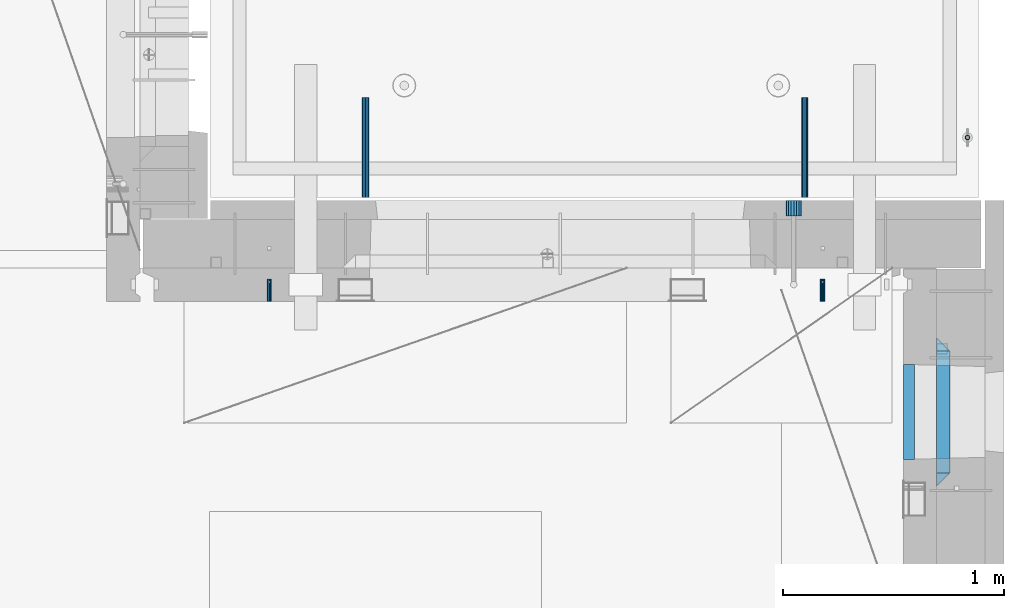
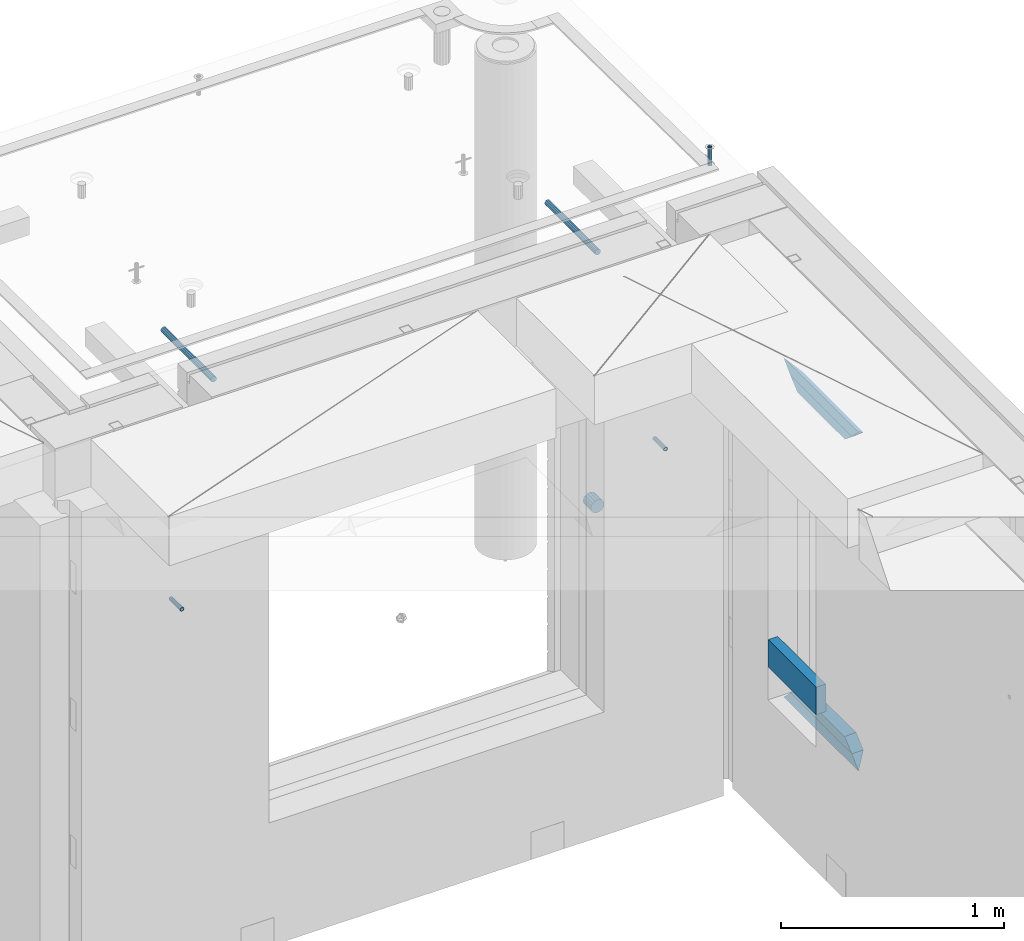
# One storey, part 163 of 334: 11 beams, 8 elements without a shape of their own.
"""IFC2X3 building model written with IfcOpenShell, lengths in millimetres."""

from ifc_helpers import new_model, si_unit, frame, origin_with_axes, place, context, subcontext, project, spatial, faceted_brep, material, type_object, element, aggregate, save


model = new_model("IFC2X3")

# Units and contexts
model_context = context("Model", 3, precision=1e-05, world=origin_with_axes())
body_context = subcontext(model_context, "Body", "Model", "MODEL_VIEW")
ifc_project = project(units=[si_unit("LENGTHUNIT", "METRE", prefix="MILLI"), si_unit("AREAUNIT", "SQUARE_METRE"), si_unit("VOLUMEUNIT", "CUBIC_METRE"), si_unit("MASSUNIT", "GRAM", prefix="KILO"), si_unit("TIMEUNIT", "SECOND"), si_unit("PLANEANGLEUNIT", "RADIAN"), si_unit("SOLIDANGLEUNIT", "STERADIAN"), si_unit("THERMODYNAMICTEMPERATUREUNIT", "DEGREE_CELSIUS"), si_unit("LUMINOUSINTENSITYUNIT", "LUMEN")], contexts=[model_context])

# Site, building, storey
site_placement = place(None, origin_with_axes())
site = spatial("IfcSite", under=ifc_project, at=site_placement, CompositionType="ELEMENT")
building_placement = place(site_placement, origin_with_axes())
building = spatial("IfcBuilding", under=site, at=building_placement, CompositionType="ELEMENT")
storey_placement = place(building_placement, origin_with_axes())
storey = spatial("IfcBuildingStorey", under=building, at=storey_placement, Name="3", CompositionType="ELEMENT", Elevation=0.0)

# Assemblies, beams
assembly_1_placement = place(storey_placement, origin_with_axes())
assembly_1 = element("IfcElementAssembly", 1, at=assembly_1_placement, inside=storey, AssemblyPlace="NOTDEFINED", PredefinedType="REINFORCEMENT_UNIT")
assembly_2_placement = place(assembly_1_placement, origin_with_axes())
assembly_2 = element("IfcElementAssembly", 2, at=assembly_2_placement, Name="Steel Assembly", AssemblyPlace="NOTDEFINED", PredefinedType="RIGID_FRAME")
ifc_material_1 = material(Name="STEEL/Steel_Undefined")
beam_type_1 = type_object("IfcBeamType", PredefinedType="NOTDEFINED")
beam_1_placement = place(assembly_2_placement, frame((32044.9982931989, 20429.9951872276, 89755.0), z_axis=(1.0, 0.0, 0.0), x_axis=(0.0, 1.0, 0.0)))
beam_1 = element("IfcBeam", 3, at=beam_1_placement, type_object=beam_type_1, material=ifc_material_1, Name="M16", context=body_context, shape_type="Brep", body=[
    faceted_brep([(0.0, -8.49999999999272, -1.45519152283669e-11), (0.0, -7.36121593215648, 4.24999999998545), (100.000000000262, -7.36121593215648, 4.24999999998545), (100.000000000262, -8.49999999999272, -1.45519152283669e-11), (0.0, -4.24999999998545, 7.36121593216376), (100.000000000262, -4.24999999998545, 7.36121593216376), (0.0, 1.45519152283669e-11, 8.49999999998545), (100.000000000262, 1.45519152283669e-11, 8.49999999998545), (0.0, 4.25000000001455, 7.36121593216376), (100.000000000262, 4.25000000001455, 7.36121593216376), (0.0, 7.36121593217104, 4.24999999998545), (100.000000000262, 7.36121593217104, 4.24999999998545), (0.0, 8.50000000000728, 0.0), (100.000000000262, 8.50000000000728, 0.0), (0.0, 7.36121593217104, -4.25000000001455), (100.000000000262, 7.36121593217104, -4.25000000001455), (0.0, 4.25000000000728, -7.36121593219286), (100.000000000262, 4.25000000000728, -7.36121593219286), (0.0, 7.27595761418343e-12, -8.5), (100.000000000262, 7.27595761418343e-12, -8.5), (0.0, -4.24999999999272, -7.36121593217831), (100.000000000262, -4.24999999999272, -7.36121593217831), (0.0, -7.36121593215648, -4.25), (100.000000000262, -7.36121593215648, -4.25), (0.0, -10.4999999999927, -1.45519152283669e-11), (0.0, -9.09326673972828, -5.25000000001455), (100.000000000262, -9.09326673972828, -5.25000000001455), (100.000000000262, -10.4999999999927, -1.45519152283669e-11), (0.0, -5.24999999998545, -9.09326673974283), (100.000000000262, -5.24999999998545, -9.09326673974283), (0.0, 7.27595761418343e-12, -10.5), (100.000000000262, 7.27595761418343e-12, -10.5), (0.0, 5.25000000001455, -9.09326673975738), (100.000000000262, 5.25000000001455, -9.09326673975738), (0.0, 9.09326673975011, -5.25000000001455), (100.000000000262, 9.09326673975011, -5.25000000001455), (0.0, 10.5000000000073, -1.45519152283669e-11), (100.000000000262, 10.5000000000073, -1.45519152283669e-11), (0.0, 9.09326673975011, 5.25), (100.000000000262, 9.09326673975011, 5.25), (0.0, 5.25000000000728, 9.09326673972828), (100.000000000262, 5.25000000000728, 9.09326673972828), (0.0, 1.45519152283669e-11, 10.4999999999854), (100.000000000262, 1.45519152283669e-11, 10.4999999999854), (0.0, -5.24999999999272, 9.09326673972828), (100.000000000262, -5.24999999999272, 9.09326673972828), (0.0, -9.09326673972828, 5.24999999998545), (100.000000000262, -9.09326673972828, 5.24999999998545)], [[[0, 1, 2, 3]], [[1, 4, 5, 2]], [[4, 6, 7, 5]], [[6, 8, 9, 7]], [[8, 10, 11, 9]], [[10, 12, 13, 11]], [[12, 14, 15, 13]], [[14, 16, 17, 15]], [[16, 18, 19, 17]], [[18, 20, 21, 19]], [[20, 22, 23, 21]], [[22, 0, 3, 23]], [[24, 25, 26, 27]], [[25, 28, 29, 26]], [[28, 30, 31, 29]], [[30, 32, 33, 31]], [[32, 34, 35, 33]], [[34, 36, 37, 35]], [[36, 38, 39, 37]], [[38, 40, 41, 39]], [[40, 42, 43, 41]], [[42, 44, 45, 43]], [[44, 46, 47, 45]], [[46, 24, 27, 47]], [[29, 31, 33, 35, 37, 39, 41, 43, 45, 47, 27, 26], [5, 7, 9, 11, 13, 15, 17, 19, 21, 23, 3, 2]], [[46, 44, 42, 40, 38, 36, 34, 32, 30, 28, 25, 24], [22, 20, 18, 16, 14, 12, 10, 8, 6, 4, 1, 0]]]),
])
aggregate(assembly_2, [beam_1])
assembly_3_placement = place(assembly_1_placement, origin_with_axes())
assembly_3 = element("IfcElementAssembly", 4, at=assembly_3_placement, Name="Steel Assembly", AssemblyPlace="NOTDEFINED", PredefinedType="RIGID_FRAME")
beam_2_placement = place(assembly_3_placement, frame((34544.998293199, 20429.9951872276, 89755.0), z_axis=(1.0, 0.0, 0.0), x_axis=(0.0, 1.0, 0.0)))
beam_2 = element("IfcBeam", 5, at=beam_2_placement, type_object=beam_type_1, material=ifc_material_1, Name="M16", context=body_context, shape_type="Brep", body=[
    faceted_brep([(0.0, -8.49999999999272, -1.45519152283669e-11), (0.0, -7.36121593215648, 4.24999999998545), (100.000000000262, -7.36121593215648, 4.24999999998545), (100.000000000262, -8.49999999999272, -1.45519152283669e-11), (0.0, -4.24999999998545, 7.36121593216376), (100.000000000262, -4.24999999998545, 7.36121593216376), (0.0, 1.45519152283669e-11, 8.49999999998545), (100.000000000262, 1.45519152283669e-11, 8.49999999998545), (0.0, 4.25000000001455, 7.36121593216376), (100.000000000262, 4.25000000001455, 7.36121593216376), (0.0, 7.36121593217104, 4.24999999998545), (100.000000000262, 7.36121593217104, 4.24999999998545), (0.0, 8.50000000000728, 0.0), (100.000000000262, 8.50000000000728, 0.0), (0.0, 7.36121593217104, -4.25000000001455), (100.000000000262, 7.36121593217104, -4.25000000001455), (0.0, 4.25000000000728, -7.36121593219286), (100.000000000262, 4.25000000000728, -7.36121593219286), (0.0, 7.27595761418343e-12, -8.5), (100.000000000262, 7.27595761418343e-12, -8.5), (0.0, -4.24999999999272, -7.36121593217831), (100.000000000262, -4.24999999999272, -7.36121593217831), (0.0, -7.36121593215648, -4.25), (100.000000000262, -7.36121593215648, -4.25), (0.0, -10.4999999999927, -1.45519152283669e-11), (0.0, -9.09326673972828, -5.25000000001455), (100.000000000262, -9.09326673972828, -5.25000000001455), (100.000000000262, -10.4999999999927, -1.45519152283669e-11), (0.0, -5.24999999998545, -9.09326673974283), (100.000000000262, -5.24999999998545, -9.09326673974283), (0.0, 7.27595761418343e-12, -10.5), (100.000000000262, 7.27595761418343e-12, -10.5), (0.0, 5.25000000001455, -9.09326673975738), (100.000000000262, 5.25000000001455, -9.09326673975738), (0.0, 9.09326673975011, -5.25000000001455), (100.000000000262, 9.09326673975011, -5.25000000001455), (0.0, 10.5000000000073, -1.45519152283669e-11), (100.000000000262, 10.5000000000073, -1.45519152283669e-11), (0.0, 9.09326673975011, 5.25), (100.000000000262, 9.09326673975011, 5.25), (0.0, 5.25000000000728, 9.09326673972828), (100.000000000262, 5.25000000000728, 9.09326673972828), (0.0, 1.45519152283669e-11, 10.4999999999854), (100.000000000262, 1.45519152283669e-11, 10.4999999999854), (0.0, -5.24999999999272, 9.09326673972828), (100.000000000262, -5.24999999999272, 9.09326673972828), (0.0, -9.09326673972828, 5.24999999998545), (100.000000000262, -9.09326673972828, 5.24999999998545)], [[[0, 1, 2, 3]], [[1, 4, 5, 2]], [[4, 6, 7, 5]], [[6, 8, 9, 7]], [[8, 10, 11, 9]], [[10, 12, 13, 11]], [[12, 14, 15, 13]], [[14, 16, 17, 15]], [[16, 18, 19, 17]], [[18, 20, 21, 19]], [[20, 22, 23, 21]], [[22, 0, 3, 23]], [[24, 25, 26, 27]], [[25, 28, 29, 26]], [[28, 30, 31, 29]], [[30, 32, 33, 31]], [[32, 34, 35, 33]], [[34, 36, 37, 35]], [[36, 38, 39, 37]], [[38, 40, 41, 39]], [[40, 42, 43, 41]], [[42, 44, 45, 43]], [[44, 46, 47, 45]], [[46, 24, 27, 47]], [[29, 31, 33, 35, 37, 39, 41, 43, 45, 47, 27, 26], [5, 7, 9, 11, 13, 15, 17, 19, 21, 23, 3, 2]], [[46, 44, 42, 40, 38, 36, 34, 32, 30, 28, 25, 24], [22, 20, 18, 16, 14, 12, 10, 8, 6, 4, 1, 0]]]),
])
aggregate(assembly_3, [beam_2])

# Assemblies, beam
assembly_4_placement = place(storey_placement, origin_with_axes())
assembly_4 = element("IfcElementAssembly", 6, at=assembly_4_placement, inside=storey, AssemblyPlace="NOTDEFINED", PredefinedType="REINFORCEMENT_UNIT")
assembly_5_placement = place(assembly_4_placement, origin_with_axes())
assembly_5 = element("IfcElementAssembly", 7, at=assembly_5_placement, Name="Steel Assembly", AssemblyPlace="NOTDEFINED", PredefinedType="RIGID_FRAME")
ifc_material_2 = material(Name="STEEL/1.4301")
beam_type_2 = type_object("IfcBeamType", PredefinedType="NOTDEFINED")
beam_3_placement = place(assembly_5_placement, frame((35199.9998195516, 21170.0002421324, 90731.000000009), z_axis=(0.999999999984675, 3.40399999908427e-06, -4.36599999368485e-06), x_axis=(-4.36599999292741e-06, 0.0, -0.999999999990469)))
beam_3 = element("IfcBeam", 8, at=beam_3_placement, type_object=beam_type_2, material=ifc_material_2, context=body_context, shape_type="Brep", body=[
    faceted_brep([(0.0, -8.0, 0.0), (0.0, -6.92820323027263, 4.0), (100.000000000029, -6.92820323027263, 4.0), (100.000000000029, -7.99999999999636, 0.0), (0.0, -4.0, 6.92820323027627), (100.000000000029, -4.0, 6.92820323027536), (0.0, 0.0, 8.0), (100.000000000029, 3.63797880709171e-12, 8.0), (0.0, 4.0, 6.92820323027627), (100.000000000029, 4.0, 6.92820323027536), (0.0, 6.92820323027263, 4.0), (100.000000000029, 6.92820323027627, 3.99999999999909), (0.0, 8.0, 0.0), (100.000000000029, 8.0, 0.0), (0.0, 6.92820323027263, -4.0), (100.000000000029, 6.92820323027627, -4.00000000000091), (0.0, 4.0, -6.92820323027627), (100.000000000029, 4.00000000000364, -6.92820323027536), (0.0, 0.0, -8.0), (100.000000000029, 3.63797880709171e-12, -8.00000000000091), (0.0, -4.0, -6.92820323027627), (100.000000000029, -3.99999999999636, -6.92820323027627), (0.0, -6.92820323027263, -4.0), (100.000000000029, -6.92820323027263, -4.0), (0.0, -10.4999999999927, -1.45519152283669e-11), (0.0, -9.09326673972828, -5.25000000001455), (100.000000000262, -9.09326673972828, -5.25000000001455), (100.000000000262, -10.4999999999927, -1.45519152283669e-11), (0.0, -5.24999999998545, -9.09326673974283), (100.000000000262, -5.24999999998545, -9.09326673974283), (0.0, 7.27595761418343e-12, -10.5), (100.000000000262, 7.27595761418343e-12, -10.5), (0.0, 5.25000000001455, -9.09326673975738), (100.000000000262, 5.25000000001455, -9.09326673975738), (0.0, 9.09326673975011, -5.25000000001455), (100.000000000262, 9.09326673975011, -5.25000000001455), (0.0, 10.5000000000073, -1.45519152283669e-11), (100.000000000262, 10.5000000000073, -1.45519152283669e-11), (0.0, 9.09326673975011, 5.25), (100.000000000262, 9.09326673975011, 5.25), (0.0, 5.25000000000728, 9.09326673972828), (100.000000000262, 5.25000000000728, 9.09326673972828), (0.0, 1.45519152283669e-11, 10.4999999999854), (100.000000000262, 1.45519152283669e-11, 10.4999999999854), (0.0, -5.24999999999272, 9.09326673972828), (100.000000000262, -5.24999999999272, 9.09326673972828), (0.0, -9.09326673972828, 5.24999999998545), (100.000000000262, -9.09326673972828, 5.24999999998545)], [[[0, 1, 2, 3]], [[1, 4, 5, 2]], [[4, 6, 7, 5]], [[6, 8, 9, 7]], [[8, 10, 11, 9]], [[10, 12, 13, 11]], [[12, 14, 15, 13]], [[14, 16, 17, 15]], [[16, 18, 19, 17]], [[18, 20, 21, 19]], [[20, 22, 23, 21]], [[22, 0, 3, 23]], [[24, 25, 26, 27]], [[25, 28, 29, 26]], [[28, 30, 31, 29]], [[30, 32, 33, 31]], [[32, 34, 35, 33]], [[34, 36, 37, 35]], [[36, 38, 39, 37]], [[38, 40, 41, 39]], [[40, 42, 43, 41]], [[42, 44, 45, 43]], [[44, 46, 47, 45]], [[46, 24, 27, 47]], [[29, 31, 33, 35, 37, 39, 41, 43, 45, 47, 27, 26], [5, 7, 9, 11, 13, 15, 17, 19, 21, 23, 3, 2]], [[46, 44, 42, 40, 38, 36, 34, 32, 30, 28, 25, 24], [22, 20, 18, 16, 14, 12, 10, 8, 6, 4, 1, 0]]]),
])
aggregate(assembly_5, [beam_3])

# Beam
ifc_material_3 = material()
beam_type_3 = type_object("IfcBeamType", Name="D70", PredefinedType="NOTDEFINED")
beam_4_placement = place(assembly_1_placement, frame((34415.0, 20884.9951872276, 89255.0), z_axis=(0.0, 0.0, 1.0), x_axis=(0.0, -1.0, 0.0)))
beam_4 = element("IfcBeam", 9, at=beam_4_placement, type_object=beam_type_3, material=ifc_material_3, ObjectType="D70", context=body_context, shape_type="Brep", body=[
    faceted_brep([(0.0, -35.0, 0.0), (0.0, -32.3357836378964, -13.3939201327739), (70.0, -32.3357836378964, -13.3939201327739), (70.0, -35.0, 0.0), (0.0, -24.7487373415279, -24.7487373415352), (70.0, -24.7487373415279, -24.7487373415352), (0.0, -13.3939201327776, -32.3357836379), (70.0, -13.3939201327776, -32.3357836379), (0.0, 0.0, -35.0), (70.0, 0.0, -35.0), (0.0, 13.3939201327776, -32.3357836379), (70.0, 13.3939201327776, -32.3357836379), (0.0, 24.7487373415279, -24.7487373415352), (70.0, 24.7487373415279, -24.7487373415352), (0.0, 32.3357836378964, -13.3939201327739), (70.0, 32.3357836378964, -13.3939201327739), (0.0, 35.0, 0.0), (70.0, 35.0, 0.0), (0.0, 32.3357836378964, 13.3939201327739), (70.0, 32.3357836378964, 13.3939201327739), (0.0, 24.7487373415279, 24.7487373415352), (70.0, 24.7487373415279, 24.7487373415352), (0.0, 13.3939201327776, 32.3357836379), (70.0, 13.3939201327776, 32.3357836379), (0.0, 0.0, 35.0), (70.0, 0.0, 35.0), (0.0, -13.3939201327776, 32.3357836379), (70.0, -13.3939201327776, 32.3357836379), (0.0, -24.7487373415279, 24.7487373415352), (70.0, -24.7487373415279, 24.7487373415352), (0.0, -32.3357836378964, 13.3939201327739), (70.0, -32.3357836378964, 13.3939201327739)], [[[0, 1, 2, 3]], [[1, 4, 5, 2]], [[4, 6, 7, 5]], [[6, 8, 9, 7]], [[8, 10, 11, 9]], [[10, 12, 13, 11]], [[12, 14, 15, 13]], [[14, 16, 17, 15]], [[16, 18, 19, 17]], [[18, 20, 21, 19]], [[20, 22, 23, 21]], [[22, 24, 25, 23]], [[24, 26, 27, 25]], [[26, 28, 29, 27]], [[28, 30, 31, 29]], [[30, 0, 3, 31]], [[5, 7, 9, 11, 13, 15, 17, 19, 21, 23, 25, 27, 29, 31, 3, 2]], [[30, 28, 26, 24, 22, 20, 18, 16, 14, 12, 10, 8, 6, 4, 1, 0]]]),
])

aggregate(assembly_1, [assembly_2, assembly_3, beam_4])

# Assembly, beam
assembly_6_placement = place(assembly_4_placement, origin_with_axes())
assembly_6 = element("IfcElementAssembly", 10, at=assembly_6_placement, Name="Steel Assembly", AssemblyPlace="NOTDEFINED", PredefinedType="RIGID_FRAME")
ifc_material_4 = material(Name="STEEL/S235JR")
beam_type_4 = type_object("IfcBeamType", Name="D30", PredefinedType="NOTDEFINED")
beam_5_placement = place(assembly_6_placement, frame((32479.9998567563, 20900.0253394533, 90575.0), z_axis=(0.0, 0.0, 1.0), x_axis=(0.0, 1.0, 0.0)))
beam_5 = element("IfcBeam", 11, at=beam_5_placement, type_object=beam_type_4, material=ifc_material_4, Name="Rd30", ObjectType="D30", context=body_context, shape_type="Brep", body=[
    faceted_brep([(0.0, -15.0, 0.0), (0.0, -12.9903810567666, -7.5), (450.0, -12.9903810567666, -7.5), (450.0, -15.0, 0.0), (0.0, -7.5, -12.9903810567666), (450.0, -7.5, -12.990381056763), (0.0, 0.0, -15.0), (450.0, 0.0, -15.0), (0.0, 7.5, -12.9903810567666), (450.0, 7.5, -12.990381056763), (0.0, 12.9903810567666, -7.5), (450.0, 12.9903810567666, -7.5), (0.0, 15.0, 0.0), (450.0, 15.0, 0.0), (0.0, 12.9903810567666, 7.5), (450.0, 12.9903810567666, 7.5), (0.0, 7.5, 12.9903810567666), (450.0, 7.5, 12.990381056763), (0.0, 0.0, 15.0), (450.0, 0.0, 15.0), (0.0, -7.5, 12.9903810567666), (450.0, -7.5, 12.990381056763), (0.0, -12.9903810567666, 7.5), (450.0, -12.9903810567666, 7.5)], [[[0, 1, 2, 3]], [[1, 4, 5, 2]], [[4, 6, 7, 5]], [[6, 8, 9, 7]], [[8, 10, 11, 9]], [[10, 12, 13, 11]], [[12, 14, 15, 13]], [[14, 16, 17, 15]], [[16, 18, 19, 17]], [[18, 20, 21, 19]], [[20, 22, 23, 21]], [[22, 0, 3, 23]], [[5, 7, 9, 11, 13, 15, 17, 19, 21, 23, 3, 2]], [[22, 20, 18, 16, 14, 12, 10, 8, 6, 4, 1, 0]]]),
])
aggregate(assembly_6, [beam_5])

# Assembly
assembly_7_placement = place(assembly_4_placement, origin_with_axes())
assembly_7 = element("IfcElementAssembly", 12, at=assembly_7_placement, Name="Steel Assembly", AssemblyPlace="NOTDEFINED", PredefinedType="RIGID_FRAME")

aggregate(assembly_4, [assembly_5, assembly_6, assembly_7])

# Beam
beam_6_placement = place(assembly_7_placement, frame((34464.9998570066, 20900.0152136098, 90575.0), z_axis=(0.0, 0.0, 1.0), x_axis=(0.0, 1.0, 0.0)))
beam_6 = element("IfcBeam", 13, at=beam_6_placement, type_object=beam_type_4, material=ifc_material_4, Name="Rd30", ObjectType="D30", context=body_context, shape_type="Brep", body=[
    faceted_brep([(0.0, -15.0, 0.0), (0.0, -12.9903810567666, -7.5), (450.0, -12.9903810567666, -7.5), (450.0, -15.0, 0.0), (0.0, -7.5, -12.9903810567666), (450.0, -7.5, -12.990381056763), (0.0, 0.0, -15.0), (450.0, 0.0, -15.0), (0.0, 7.5, -12.9903810567666), (450.0, 7.5, -12.990381056763), (0.0, 12.9903810567666, -7.5), (450.0, 12.9903810567666, -7.5), (0.0, 15.0, 0.0), (450.0, 15.0, 0.0), (0.0, 12.9903810567666, 7.5), (450.0, 12.9903810567666, 7.5), (0.0, 7.5, 12.9903810567666), (450.0, 7.5, 12.990381056763), (0.0, 0.0, 15.0), (450.0, 0.0, 15.0), (0.0, -7.5, 12.9903810567666), (450.0, -7.5, 12.990381056763), (0.0, -12.9903810567666, 7.5), (450.0, -12.9903810567666, 7.5)], [[[0, 1, 2, 3]], [[1, 4, 5, 2]], [[4, 6, 7, 5]], [[6, 8, 9, 7]], [[8, 10, 11, 9]], [[10, 12, 13, 11]], [[12, 14, 15, 13]], [[14, 16, 17, 15]], [[16, 18, 19, 17]], [[18, 20, 21, 19]], [[20, 22, 23, 21]], [[22, 0, 3, 23]], [[5, 7, 9, 11, 13, 15, 17, 19, 21, 23, 3, 2]], [[22, 20, 18, 16, 14, 12, 10, 8, 6, 4, 1, 0]]]),
])

aggregate(assembly_7, [beam_6])

# Assembly, beams
assembly_8_placement = place(storey_placement, origin_with_axes())
assembly_8 = element("IfcElementAssembly", 14, at=assembly_8_placement, inside=storey, AssemblyPlace="NOTDEFINED", PredefinedType="REINFORCEMENT_UNIT")
ifc_material_5 = material(Name="TIMBER/T24")
beam_type_5 = type_object("IfcBeamType", PredefinedType="NOTDEFINED")
beam_7_placement = place(assembly_8_placement, frame((34935.0002758707, 19715.0011464907, 88685.0), z_axis=(0.0, 0.0, 1.0), x_axis=(0.0, 1.0, 0.0)))
beam_7 = element("IfcBeam", 15, at=beam_7_placement, type_object=beam_type_5, material=ifc_material_5, context=body_context, shape_type="Brep", body=[
    faceted_brep([(-3.63797880709171e-12, 24.9999999999964, -75.0), (-3.63797880709171e-12, 24.9999999999964, 75.0), (430.0, 25.0, 75.0), (430.0, 25.0, -75.0), (0.0, -25.0000000000073, 75.0), (430.0, -25.0, 75.0), (0.0, -25.0000000000073, -75.0), (430.0, -25.0, -75.0)], [[[0, 1, 2, 3]], [[1, 4, 5, 2]], [[4, 6, 7, 5]], [[6, 0, 3, 7]], [[5, 7, 3, 2]], [[6, 4, 1, 0]]]),
])
ifc_material_6 = material(Name="CONCRETE/C25/30")
beam_type_6 = type_object("IfcBeamType", PredefinedType="NOTDEFINED")
beam_8_placement = place(assembly_8_placement, frame((35090.0, 19595.0003479451, 90145.0), z_axis=(0.0, 0.0, -1.0), x_axis=(0.0, 1.0, 0.0)))
beam_8 = element("IfcBeam", 16, at=beam_8_placement, type_object=beam_type_6, material=ifc_material_6, Name="SK", context=body_context, shape_type="Brep", body=[
    faceted_brep([(60.0000000000073, 30.0, 30.0), (0.0, -30.0, -30.0), (60.0000000000073, -30.0, 30.0), (609.999618530263, 30.0, 30.0), (669.999575761092, -30.0, -30.0), (609.999618530263, -30.0, 30.0)], [[[0, 1, 2]], [[1, 0, 3, 4]], [[2, 1, 4, 5]], [[0, 2, 5, 3]], [[4, 3, 5]]]),
])
beam_9_placement = place(assembly_8_placement, frame((35090.0, 19655.0003479451, 90085.0), z_axis=(0.0, 0.0, -1.0), x_axis=(0.0, 1.0, 0.0)))
beam_9 = element("IfcBeam", 17, at=beam_9_placement, type_object=beam_type_6, material=ifc_material_6, Name="SK", context=body_context, shape_type="Brep", body=[
    faceted_brep([(65.6752942059502, 30.0, 25.6756756756804), (64.0536725843267, -30.0, 24.0540540540533), (485.94556447622, -30.0, 24.0540540540533), (484.323942854597, 30.0, 25.6756756756804), (65.6752942059502, 30.0, 26.293109307022), (64.0536725843267, -30.0, 24.9031479173718), (0.0, -30.0, -30.0), (0.0, 30.0, -30.0), (549.999575761092, 29.999999998452, -30.0), (549.999575761092, -29.999999998452, -30.0), (485.94556447622, -30.0, 24.9034748914273), (484.323942854597, 30.0, 26.293436281092)], [[[0, 1, 2, 3]], [[1, 0, 4, 5]], [[6, 5, 4, 7]], [[6, 7, 8, 9]], [[2, 1, 5, 6, 9, 10]], [[3, 2, 10, 11]], [[7, 4, 0, 3, 11, 8]], [[10, 9, 8, 11]]]),
])
beam_10_placement = place(assembly_8_placement, frame((35090.0, 20264.9999664753, 88350.0), z_axis=(0.0, 0.0, 1.0), x_axis=(0.0, -1.0, 0.0)))
beam_10 = element("IfcBeam", 18, at=beam_10_placement, type_object=beam_type_6, material=ifc_material_6, Name="SK", context=body_context, shape_type="Brep", body=[
    faceted_brep([(669.999575761092, -30.0, -30.0), (609.999618530263, 30.0, 30.0), (609.999618530263, -30.0, 30.0), (60.0000000000073, 30.0, 30.0), (60.0000000000073, -30.0, 30.0), (0.0, -30.0, -30.0)], [[[0, 1, 2]], [[3, 4, 2, 1]], [[4, 5, 0, 2]], [[5, 3, 1, 0]], [[3, 5, 4]]]),
])
beam_11_placement = place(assembly_8_placement, frame((35090.0, 20204.9999664753, 88410.0), z_axis=(0.0, 0.0, 1.0), x_axis=(0.0, -1.0, 0.0)))
beam_11 = element("IfcBeam", 19, at=beam_11_placement, type_object=beam_type_6, material=ifc_material_6, Name="SK", context=body_context, shape_type="Brep", body=[
    faceted_brep([(485.945945945947, -30.0, 24.0540540540533), (484.324324324325, 30.0, 25.6756756756804), (65.6756756756768, 30.0, 25.6756756756804), (64.0540540540533, -30.0, 24.0540540540533), (485.945945945947, -30.0, 24.9031479173718), (484.324324324323, 30.0, 26.2931093070365), (549.999575761092, -29.999999998452, -30.0), (549.999575761092, 29.999999998452, -30.0), (0.0, 30.0, -30.0), (65.6756756756768, 30.0, 26.293436281092), (64.0540540540533, -30.0, 24.9034748914419), (0.0, -30.0, -30.0)], [[[0, 1, 2, 3]], [[1, 0, 4, 5]], [[6, 7, 5, 4]], [[2, 1, 5, 7, 8, 9]], [[3, 2, 9, 10]], [[6, 4, 0, 3, 10, 11]], [[11, 8, 7, 6]], [[11, 10, 9, 8]]]),
])
aggregate(assembly_8, [beam_7, beam_8, beam_9, beam_10, beam_11])

save(model, "model.ifc")
